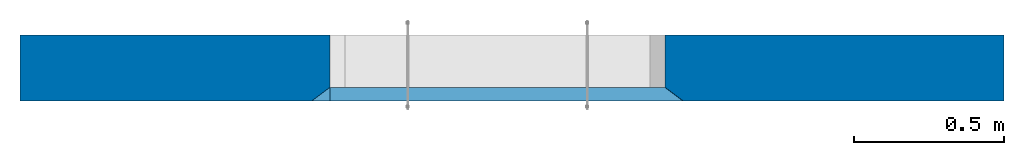
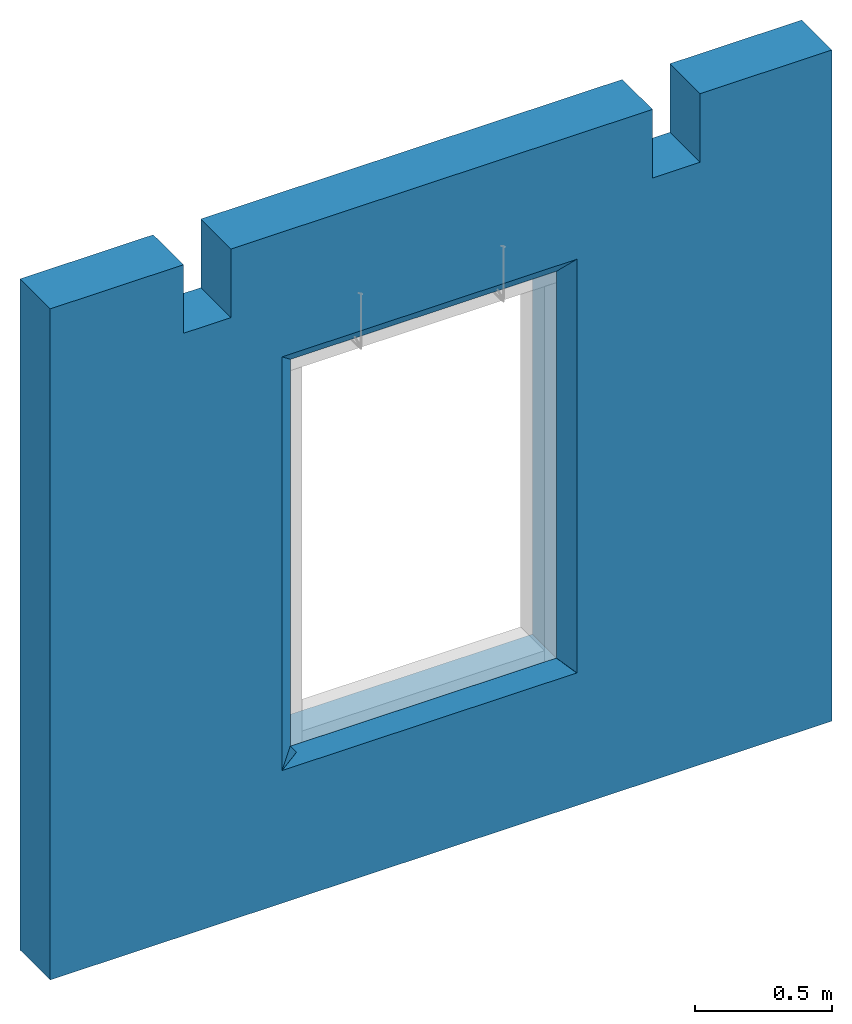
# One storey, part 4 of 4: 1 wall, 1 element without a shape of its own.
"""IFC2X3 building model written with IfcOpenShell, lengths in millimetres."""

import ifcopenshell
import ifcopenshell.guid

model = None  # the IFC model being written
_history = None  # IfcOwnerHistory: only IFC2X3 demands one
_inside = {}  # id of a spatial element -> (the spatial element, [elements in it])
_under = {}  # id of a project, library or spatial element -> (it, [spatial elements below it])
_declared = {}  # id of a project -> (the project, [libraries it declares])
_typed = {}  # id of a type object -> (the type object, [elements of that type])
_made_of = {}  # id of a material, layer set ... -> (it, [elements and type objects made of it])


def new_model(schema):
    """Start an empty IFC model of exactly this schema.

    Asked for "IFC4X3", IfcOpenShell would pick the latest addendum, in which some entities
    have other attributes; the version numbers below select the first issue.
    IFC2X3 requires an IfcOwnerHistory on every rooted entity: one is made here for all.
    """
    global model, _history
    if schema == "IFC4X3":
        model = ifcopenshell.file(schema_version=(4, 3, 0, 0))
    else:
        model = ifcopenshell.file(schema=schema)
    _inside.clear()
    _under.clear()
    _declared.clear()
    _typed.clear()
    _made_of.clear()
    _history = None
    if model.schema == "IFC2X3":
        org = make("IfcOrganization", Name="unknown")
        user = make(
            "IfcPersonAndOrganization",
            ThePerson=make("IfcPerson", FamilyName="unknown"),
            TheOrganization=org,
        )
        app = make(
            "IfcApplication",
            ApplicationDeveloper=org,
            Version="unknown",
            ApplicationFullName="unknown",
            ApplicationIdentifier="unknown",
        )
        _history = make(
            "IfcOwnerHistory",
            OwningUser=user,
            OwningApplication=app,
            ChangeAction="ADDED",
            CreationDate=0,
        )
    return model


def make(cls, **values):
    """One entity of the class cls with the attributes given. An attribute that is None is left unset."""
    return model.create_entity(
        cls, **{name: value for name, value in values.items() if value is not None}
    )


def rooted(cls, **values):
    """An entity with a GlobalId (a new one), such as an element, a storey or a relation."""
    return make(cls, GlobalId=ifcopenshell.guid.new(), OwnerHistory=_history, **values)


def si_unit(unit_type, name, prefix=None):
    """IfcSIUnit, for example si_unit("LENGTHUNIT", "METRE", prefix="MILLI")."""
    return make("IfcSIUnit", UnitType=unit_type, Prefix=prefix, Name=name)


def assignment(units):
    """IfcUnitAssignment: the units of a project."""
    return None if units is None else make("IfcUnitAssignment", Units=units)


def point(xyz):
    """IfcCartesianPoint."""
    return None if xyz is None else make("IfcCartesianPoint", Coordinates=xyz)


def direction(xyz):
    """IfcDirection."""
    return None if xyz is None else make("IfcDirection", DirectionRatios=xyz)


def frame(location, z_axis=None, x_axis=None):
    """IfcAxis2Placement3D, a coordinate frame: its origin and axes. An axis left out is left unset."""
    return make(
        "IfcAxis2Placement3D",
        Location=point(location),
        Axis=direction(z_axis),
        RefDirection=direction(x_axis),
    )


def frame_2d(location, x_axis=None):
    """IfcAxis2Placement2D, a coordinate frame in the plane: its origin and x axis."""
    return make(
        "IfcAxis2Placement2D", Location=point(location), RefDirection=direction(x_axis)
    )


def origin_with_axes():
    """The frame at (0, 0, 0) with the z axis (0, 0, 1) and the x axis (1, 0, 0) written out."""
    return frame((0.0, 0.0, 0.0), z_axis=(0.0, 0.0, 1.0), x_axis=(1.0, 0.0, 0.0))


def origin_2d_with_axis():
    """The frame at (0, 0) in the plane with the x axis (1, 0) written out."""
    return frame_2d((0.0, 0.0), x_axis=(1.0, 0.0))


def place(relative_to, where):
    """IfcLocalPlacement: puts the frame where relative to a parent placement (None: the world)."""
    return make(
        "IfcLocalPlacement", PlacementRelTo=relative_to, RelativePlacement=where
    )


def context(
    kind, dimensions, precision=None, world=None, true_north=None, identifier=None
):
    """IfcGeometricRepresentationContext, for example the 3D "Model" context."""
    return make(
        "IfcGeometricRepresentationContext",
        ContextIdentifier=identifier,
        ContextType=kind,
        CoordinateSpaceDimension=dimensions,
        Precision=precision,
        WorldCoordinateSystem=world,
        TrueNorth=true_north,
    )


def subcontext(parent, identifier, kind, view, scale=None):
    """IfcGeometricRepresentationSubContext, for example "Body" below "Model"."""
    return make(
        "IfcGeometricRepresentationSubContext",
        ContextIdentifier=identifier,
        ContextType=kind,
        ParentContext=parent,
        TargetScale=scale,
        TargetView=view,
    )


def project(units=None, contexts=None):
    """IfcProject with its units and contexts."""
    return rooted(
        "IfcProject",
        Name="project",
        RepresentationContexts=contexts,
        UnitsInContext=assignment(units),
    )


def spatial(cls, under=None, at=None, **own):
    """A site, building, storey or space (cls), placed at a placement, below another one or the project."""
    s = rooted(cls, ObjectPlacement=at, **own)
    if under is not None:
        _under.setdefault(under.id(), (under, []))[1].append(s)
    return s


def polyline(points):
    """IfcPolyline through the points."""
    return make("IfcPolyline", Points=[point(p) for p in points])


def profile(cls, at=None, kind="AREA", **sizes):
    """A parametric profile (cls). Its sizes go by their IFC names, for example OverallWidth=200.0."""
    return make(cls, ProfileType=kind, Position=at, **sizes)


def rectangle(**sizes):
    """IfcRectangleProfileDef."""
    return profile("IfcRectangleProfileDef", **sizes)


def outline(outer, holes=None, kind="AREA"):
    """IfcArbitraryClosedProfileDef: a profile drawn as a closed curve; with holes, ...WithVoids."""
    if holes is None:
        return make("IfcArbitraryClosedProfileDef", ProfileType=kind, OuterCurve=outer)
    return make(
        "IfcArbitraryProfileDefWithVoids",
        ProfileType=kind,
        OuterCurve=outer,
        InnerCurves=holes,
    )


def extrude(swept, where, along, depth):
    """IfcExtrudedAreaSolid: the profile swept, set in the frame where, extruded along a direction by depth."""
    return make(
        "IfcExtrudedAreaSolid",
        SweptArea=swept,
        Position=where,
        ExtrudedDirection=direction(along),
        Depth=depth,
    )


def boolean(op, a, b):
    """IfcBooleanResult of two solids."""
    return make("IfcBooleanResult", Operator=op, FirstOperand=a, SecondOperand=b)


def halfspace(plane, agree):
    """IfcHalfSpaceSolid: all space on one side of the plane z = 0 of the frame plane."""
    return make(
        "IfcHalfSpaceSolid",
        BaseSurface=make("IfcPlane", Position=plane),
        AgreementFlag=agree,
    )


def faces_of(points, faces, orient=None, outer=None):
    """IfcFace entities. A face is a list of loops; a loop is a list of indices into points, from 0.

    orient and outer hold one flag for each loop. By default every Orientation is true, the
    first loop of a face is its IfcFaceOuterBound and the others are IfcFaceBound.
    """
    made = []
    for i, loops in enumerate(faces):
        bounds = []
        for j, loop in enumerate(loops):
            is_outer = j == 0 if outer is None else outer[i][j]
            bounds.append(
                make(
                    "IfcFaceOuterBound" if is_outer else "IfcFaceBound",
                    Bound=make("IfcPolyLoop", Polygon=[points[k] for k in loop]),
                    Orientation=True if orient is None else orient[i][j],
                )
            )
        made.append(make("IfcFace", Bounds=bounds))
    return made


def faceted_brep(points, faces, orient=None, outer=None, voids=None):
    """IfcFacetedBrep: a solid bounded by flat faces; with voids (closed shells), ...WithVoids."""
    shared = [point(p) for p in points]
    hull = make("IfcClosedShell", CfsFaces=faces_of(shared, faces, orient, outer))
    if voids is None:
        return make("IfcFacetedBrep", Outer=hull)
    return make(
        "IfcFacetedBrepWithVoids",
        Outer=hull,
        Voids=[
            make(cls, CfsFaces=faces_of(shared, fs, o, b)) for cls, fs, o, b in voids
        ],
    )


def shape(context_of_items, identifier, shape_type, items):
    """IfcShapeRepresentation: the items that make up one representation, for example the "Body"."""
    return make(
        "IfcShapeRepresentation",
        ContextOfItems=context_of_items,
        RepresentationIdentifier=identifier,
        RepresentationType=shape_type,
        Items=items,
    )


def material(Name=None, Category=None):
    """IfcMaterial."""
    return make("IfcMaterial", Name=Name, Category=Category)


def made_of(thing, what):
    """Note that an element or type object is made of a material, layer set ...; save() writes the relation."""
    if what is not None:
        _made_of.setdefault(what.id(), (what, []))[1].append(thing)
    return thing


def type_object(cls, material=None, **own):
    """A type object (cls), such as IfcWallType, which elements share."""
    return made_of(rooted(cls, **own), material)


def element(
    cls,
    number,
    at=None,
    inside=None,
    cuts=None,
    type_object=None,
    material=None,
    context=None,
    identifier="Body",
    shape_type=None,
    held_by="IfcProductDefinitionShape",
    body=None,
    shapes=None,
    **own,
):
    """One element of the class cls, such as IfcWall. Its Tag is "e" and its number.

    at: its placement. inside: the storey or other place that contains it. cuts: it is an
    opening in that element (IfcRelVoidsElement). A single representation is given by context,
    identifier, shape_type and body (its items); several are given by shapes. held_by: the class
    of the entity that holds the representations. save() writes the other relations.
    """
    e = rooted(cls, Tag="e%d" % number, ObjectPlacement=at, **own)
    if body is not None:
        shapes = [shape(context, identifier, shape_type, body)]
    if shapes is not None:
        e.Representation = make(held_by, Representations=shapes)
    if inside is not None:
        _inside.setdefault(inside.id(), (inside, []))[1].append(e)
    if cuts is not None:
        rooted(
            "IfcRelVoidsElement", RelatingBuildingElement=cuts, RelatedOpeningElement=e
        )
    if type_object is not None:
        _typed.setdefault(type_object.id(), (type_object, []))[1].append(e)
    return made_of(e, material)


def aggregate(whole, parts):
    """IfcRelAggregates: a whole, such as a stair, and the parts it consists of."""
    return rooted("IfcRelAggregates", RelatingObject=whole, RelatedObjects=parts)


def save(model, path):
    """Write the relations noted so far, then the file.

    IfcRelAggregates (storeys below a building ...), IfcRelContainedInSpatialStructure (elements
    in a storey), IfcRelDefinesByType, IfcRelAssociatesMaterial and IfcRelDeclares: one each for
    every whole, place, type object, material and project.
    """
    for whole, parts in _under.values():
        aggregate(whole, parts)
    for where, things in _inside.values():
        rooted(
            "IfcRelContainedInSpatialStructure",
            RelatedElements=things,
            RelatingStructure=where,
        )
    for kind, things in _typed.values():
        rooted("IfcRelDefinesByType", RelatedObjects=things, RelatingType=kind)
    for what, things in _made_of.values():
        rooted("IfcRelAssociatesMaterial", RelatedObjects=things, RelatingMaterial=what)
    for by, libraries in _declared.values():
        rooted("IfcRelDeclares", RelatingContext=by, RelatedDefinitions=libraries)
    model.write(path)


model = new_model("IFC2X3")

# Units and contexts
model_context = context("Model", 3, precision=1e-05, world=origin_with_axes())
body_context = subcontext(model_context, "Body", "Model", "MODEL_VIEW")
ifc_project = project(units=[si_unit("LENGTHUNIT", "METRE", prefix="MILLI"), si_unit("AREAUNIT", "SQUARE_METRE"), si_unit("VOLUMEUNIT", "CUBIC_METRE"), si_unit("MASSUNIT", "GRAM", prefix="KILO"), si_unit("TIMEUNIT", "SECOND"), si_unit("PLANEANGLEUNIT", "RADIAN"), si_unit("SOLIDANGLEUNIT", "STERADIAN"), si_unit("THERMODYNAMICTEMPERATUREUNIT", "DEGREE_CELSIUS"), si_unit("LUMINOUSINTENSITYUNIT", "LUMEN")], contexts=[model_context])

# Site, building, storey
site_placement = place(None, origin_with_axes())
site = spatial("IfcSite", under=ifc_project, at=site_placement, CompositionType="ELEMENT")
building_placement = place(site_placement, origin_with_axes())
building = spatial("IfcBuilding", under=site, at=building_placement, Name="C", CompositionType="ELEMENT")
storey_placement = place(building_placement, origin_with_axes())
storey = spatial("IfcBuildingStorey", under=building, at=storey_placement, Name="2", CompositionType="ELEMENT", Elevation=0.0)

# Assembly, wall
assembly_placement = place(storey_placement, origin_with_axes())
assembly = element("IfcElementAssembly", 1, at=assembly_placement, inside=storey, Name="Steel Assembly", AssemblyPlace="NOTDEFINED", PredefinedType="NOTDEFINED")
ifc_material = material(Name="COS5gt")
wall_type = type_object("IfcWallType", Name="2985X220", PredefinedType="NOTDEFINED")
wall_placement = place(assembly_placement, frame((21549.9956394852, 12259.9957159644, 6.3664629124105e-12), z_axis=(0.0, 0.0, 1.0), x_axis=(1.0, 0.0, 0.0)))
solid_1 = boolean("DIFFERENCE", boolean("DIFFERENCE", boolean("DIFFERENCE", extrude(rectangle(XDim=45.0, YDim=65.0, at=origin_2d_with_axis()), frame((2185.50061322634, -87.5003126644806, 2990.49999999999), z_axis=(0.0, 0.0, -1.0), x_axis=(0.0, 1.0, 0.0)), (0.0, 0.0, 1.0), 2900.0), halfspace(frame((2155.50061934624, -65.0003045043759, 649.50001049041), z_axis=(-0.707106781186456, 3.84666089762831e-07, -0.707106781186535), x_axis=(0.0, -1.0, 0.0)), False)), halfspace(frame((2155.50060710625, -110.000304504372, 2370.50000174977), z_axis=(-0.707106781186456, 3.84666089923608e-07, 0.707106781186535), x_axis=(0.0, 1.0, 0.0)), False)), halfspace(frame((2155.50061934634, -65.0002966379579, 2990.49999999999), z_axis=(0.600000284479962, 0.79999978663995, 0.0), x_axis=(0.0, 0.0, -1.0)), False))
solid_2 = boolean("DIFFERENCE", boolean("DIFFERENCE", boolean("DIFFERENCE", boolean("DIFFERENCE", boolean("DIFFERENCE", boolean("DIFFERENCE", boolean("DIFFERENCE", boolean("DIFFERENCE", extrude(rectangle(XDim=3288.99970000085, YDim=220.0, at=frame_2d((0.0, 1644.49985000042), x_axis=(0.0, -1.0))), frame((0.0, 0.0, 0.0), z_axis=(0.0, 0.0, 1.0), x_axis=(0.0, -1.0, 0.0)), (0.0, 0.0, 1.0), 2985.0), extrude(outline(polyline([(0.0, 0.0), (1620.0, 0.0), (1620.0, 1020.00000000022), (-3.41060513164848e-13, 1020.00000000022), (0.0, 0.0)])), frame((2105.9945455033, 184.999998375803, 699.999999999994), z_axis=(0.0, -1.0, 0.0), x_axis=(0.0, 0.0, 1.0)), (0.0, 0.0, 1.0), 450.0)), faceted_brep([(2105.99884659558, -65.0000000061391, 2320.00000000001), (2155.99884659558, -65.0000000060481, 2370.00000000001), (2155.99884659558, -65.0000000060481, 650.000000000014), (2105.99884659558, -65.0000000061391, 700.000000000014), (2215.99884659558, -110.000000006139, 2430.00000000001), (2215.99884659558, -110.000000006139, 590.000000000014), (2105.99884659559, -110.000000006139, 2320.00000000001), (2105.99884659559, -110.000000006139, 700.000000000014), (2105.99884659559, -260.000000006139, 2320.00000000001), (2105.99884659559, -260.000000006139, 700.000000000014)], [[[0, 1, 2, 3]], [[1, 4, 5, 2]], [[4, 6, 7, 5]], [[6, 8, 9, 7]], [[8, 0, 3, 9]], [[5, 7, 9, 3, 2]], [[8, 6, 4, 1, 0]]])), faceted_brep([(2105.99884659558, -65.0000000061391, 700.000000000014), (2155.99884659558, -65.0000000060481, 650.000000000014), (1035.99884659535, -65.0000000046621, 650.000000000007), (1085.99884659534, -65.0000000046621, 700.000000000007), (2215.99884659558, -110.000000006139, 590.000000000014), (975.998846595343, -110.00000000466, 590.000000000007), (2105.99884659559, -110.000000006139, 700.000000000014), (1085.99884659534, -110.000000004662, 700.000000000007), (2105.99884659559, -260.000000006139, 700.000000000014), (1085.99884659534, -260.000000004662, 700.000000000007)], [[[0, 1, 2, 3]], [[1, 4, 5, 2]], [[4, 6, 7, 5]], [[6, 8, 9, 7]], [[8, 0, 3, 9]], [[5, 7, 9, 3, 2]], [[8, 6, 4, 1, 0]]])), faceted_brep([(1085.99884659553, -65.0000000046675, 2320.00000000001), (1035.99884659553, -65.0000000046675, 2370.00000000001), (2155.99884659558, -65.0000000060481, 2370.00000000001), (2105.99884659558, -65.0000000061391, 2320.00000000001), (975.998846595528, -110.000000004666, 2430.00000000001), (2215.99884659558, -110.000000006139, 2430.00000000001), (1085.99884659553, -110.000000004668, 2320.00000000001), (2105.99884659559, -110.000000006139, 2320.00000000001), (1085.99884659553, -260.000000004668, 2320.00000000001), (2105.99884659559, -260.000000006139, 2320.00000000001)], [[[0, 1, 2, 3]], [[1, 4, 5, 2]], [[4, 6, 7, 5]], [[6, 8, 9, 7]], [[8, 0, 3, 9]], [[5, 7, 9, 3, 2]], [[8, 6, 4, 1, 0]]])), extrude(outline(polyline([(0.0, 0.0), (1720.0, 0.0), (1720.0, 1120.00000000021), (0.0, 1120.00000000021), (0.0, 0.0)])), frame((2155.99885222099, 184.99998639263, 650.000000000007), z_axis=(0.0, -1.0, 0.0), x_axis=(0.0, 0.0, 1.0)), (0.0, 0.0, 1.0), 450.0)), extrude(outline(polyline([(0.0, 0.0), (305.0, 3.96539689972997e-10), (305.0, 200.000000000444), (0.0, 200.000000000444), (0.0, 0.0)])), frame((560.568089244368, 113.001109664128, 2985.00000000002), z_axis=(0.0, -1.0, 0.0), x_axis=(0.0, 0.0, -1.0)), (0.0, 0.0, 1.0), 226.0)), extrude(outline(polyline([(0.0, 0.0), (305.0, 3.96539689972997e-10), (305.0, 200.000000000444), (0.0, 200.000000000444), (0.0, 0.0)])), frame((2533.9680892443, 113.000572899329, 2985.00000000002), z_axis=(0.0, -1.0, 0.0), x_axis=(0.0, 0.0, -1.0)), (0.0, 0.0, 1.0), 226.0)), solid_1)
solid_3 = boolean("DIFFERENCE", boolean("DIFFERENCE", boolean("DIFFERENCE", extrude(rectangle(XDim=45.0, YDim=65.0, at=origin_2d_with_axis()), frame((1005.99885096599, -87.4999918400008, 2990.49999999999), z_axis=(0.0, 0.0, -1.0), x_axis=(0.0, -1.0, 0.0)), (0.0, 0.0, 1.0), 2900.0), halfspace(frame((1035.99885708608, -64.9999999998981, 650.50001049041), z_axis=(0.707106781187084, -3.53553596031408e-07, -0.707106781185923), x_axis=(-0.707106781186456, 3.84666089762831e-07, -0.707106781186535)), False)), halfspace(frame((1035.99884484608, -109.999999999894, 2370.50000174977), z_axis=(0.707106781187084, -3.53553596031408e-07, 0.707106781185923), x_axis=(-0.707106781186456, 3.84666089923608e-07, 0.707106781186535)), False)), halfspace(frame((1035.99885708599, -64.9999921334802, 2990.49999999999), z_axis=(-0.599999849279991, 0.800000113039984, 0.0), x_axis=(-0.800000113039984, -0.599999849279991, 0.0)), False))
wall = element("IfcWall", 2, at=wall_placement, type_object=wall_type, material=ifc_material, ObjectType="2985X220", context=body_context, shape_type="CSG", body=[
    boolean("DIFFERENCE", solid_2, solid_3),
])
aggregate(assembly, [wall])

save(model, "model.ifc")
